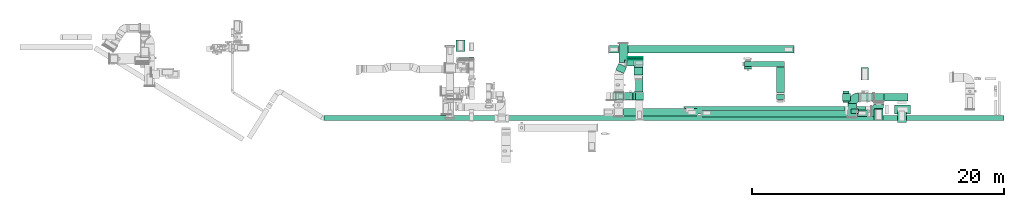
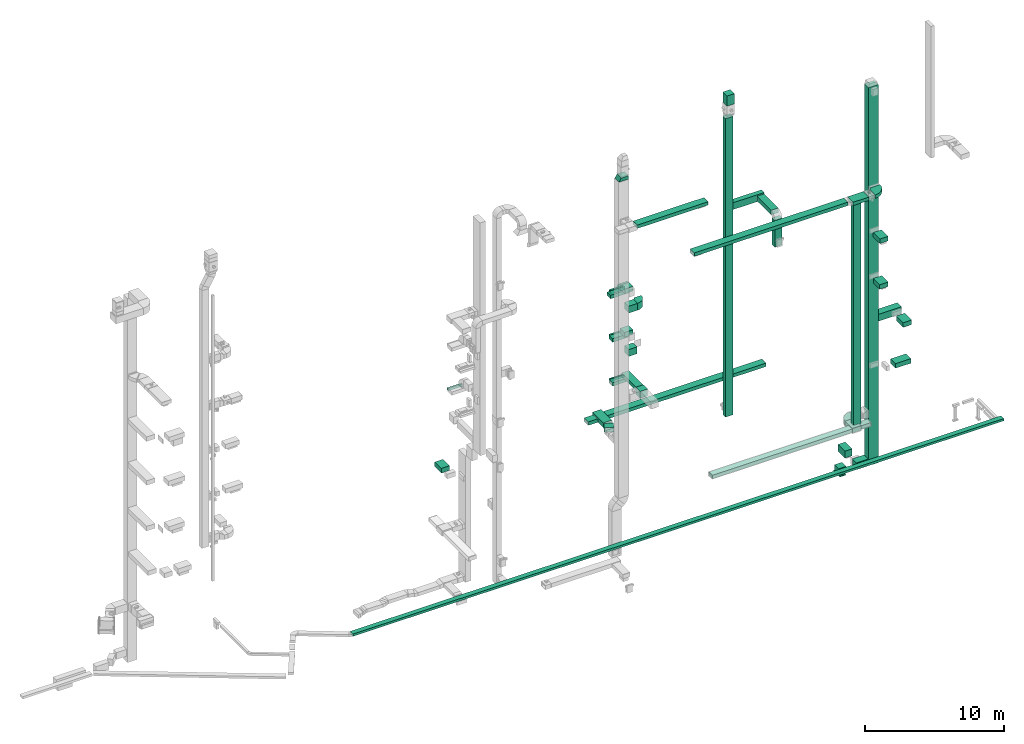
# One storey, part 8 of 29: 41 flow segments, 7 flow fittings, 2 flow terminals.
"""IFC2X3 building model written with IfcOpenShell, lengths in millimetres."""

import ifcopenshell
import ifcopenshell.guid

model = None  # the IFC model being written
_history = None  # IfcOwnerHistory: only IFC2X3 demands one
_inside = {}  # id of a spatial element -> (the spatial element, [elements in it])
_under = {}  # id of a project, library or spatial element -> (it, [spatial elements below it])
_declared = {}  # id of a project -> (the project, [libraries it declares])
_typed = {}  # id of a type object -> (the type object, [elements of that type])
_made_of = {}  # id of a material, layer set ... -> (it, [elements and type objects made of it])


def new_model(schema):
    """Start an empty IFC model of exactly this schema.

    Asked for "IFC4X3", IfcOpenShell would pick the latest addendum, in which some entities
    have other attributes; the version numbers below select the first issue.
    IFC2X3 requires an IfcOwnerHistory on every rooted entity: one is made here for all.
    """
    global model, _history
    if schema == "IFC4X3":
        model = ifcopenshell.file(schema_version=(4, 3, 0, 0))
    else:
        model = ifcopenshell.file(schema=schema)
    _inside.clear()
    _under.clear()
    _declared.clear()
    _typed.clear()
    _made_of.clear()
    _history = None
    if model.schema == "IFC2X3":
        org = make("IfcOrganization", Name="unknown")
        user = make(
            "IfcPersonAndOrganization",
            ThePerson=make("IfcPerson", FamilyName="unknown"),
            TheOrganization=org,
        )
        app = make(
            "IfcApplication",
            ApplicationDeveloper=org,
            Version="unknown",
            ApplicationFullName="unknown",
            ApplicationIdentifier="unknown",
        )
        _history = make(
            "IfcOwnerHistory",
            OwningUser=user,
            OwningApplication=app,
            ChangeAction="ADDED",
            CreationDate=0,
        )
    return model


def make(cls, **values):
    """One entity of the class cls with the attributes given. An attribute that is None is left unset."""
    return model.create_entity(
        cls, **{name: value for name, value in values.items() if value is not None}
    )


def entity(cls, *values):
    """Any entity or typed value of the class cls, its attributes in the order of the schema. None: left unset."""
    e = model.create_entity(cls)
    for i, value in enumerate(values):
        if value is not None:
            e[i] = value
    return e


def rooted(cls, **values):
    """An entity with a GlobalId (a new one), such as an element, a storey or a relation."""
    return make(cls, GlobalId=ifcopenshell.guid.new(), OwnerHistory=_history, **values)


def si_unit(unit_type, name, prefix=None):
    """IfcSIUnit, for example si_unit("LENGTHUNIT", "METRE", prefix="MILLI")."""
    return make("IfcSIUnit", UnitType=unit_type, Prefix=prefix, Name=name)


def converted_unit(unit_type, name, factor, base, dimensions=None, offset=None):
    """IfcConversionBasedUnit, such as the inch: factor (a typed value) times the base unit."""
    return make(
        "IfcConversionBasedUnit"
        if offset is None
        else "IfcConversionBasedUnitWithOffset",
        ConversionOffset=offset,
        Dimensions=None
        if dimensions is None
        else entity("IfcDimensionalExponents", *dimensions),
        UnitType=unit_type,
        Name=name,
        ConversionFactor=make(
            "IfcMeasureWithUnit", ValueComponent=factor, UnitComponent=base
        ),
    )


def derived_unit(unit_type, elements):
    """IfcDerivedUnit: a product of units, each with its exponent."""
    return make(
        "IfcDerivedUnit",
        Elements=[
            make("IfcDerivedUnitElement", Unit=unit, Exponent=power)
            for unit, power in elements
        ],
        UnitType=unit_type,
    )


def assignment(units):
    """IfcUnitAssignment: the units of a project."""
    return None if units is None else make("IfcUnitAssignment", Units=units)


def point(xyz):
    """IfcCartesianPoint."""
    return None if xyz is None else make("IfcCartesianPoint", Coordinates=xyz)


def direction(xyz):
    """IfcDirection."""
    return None if xyz is None else make("IfcDirection", DirectionRatios=xyz)


def frame(location, z_axis=None, x_axis=None):
    """IfcAxis2Placement3D, a coordinate frame: its origin and axes. An axis left out is left unset."""
    return make(
        "IfcAxis2Placement3D",
        Location=point(location),
        Axis=direction(z_axis),
        RefDirection=direction(x_axis),
    )


def frame_2d(location, x_axis=None):
    """IfcAxis2Placement2D, a coordinate frame in the plane: its origin and x axis."""
    return make(
        "IfcAxis2Placement2D", Location=point(location), RefDirection=direction(x_axis)
    )


def origin():
    """The frame at (0, 0, 0) with its axes left unset."""
    return frame((0.0, 0.0, 0.0))


def origin_2d_with_axis():
    """The frame at (0, 0) in the plane with the x axis (1, 0) written out."""
    return frame_2d((0.0, 0.0), x_axis=(1.0, 0.0))


def place(relative_to, where):
    """IfcLocalPlacement: puts the frame where relative to a parent placement (None: the world)."""
    return make(
        "IfcLocalPlacement", PlacementRelTo=relative_to, RelativePlacement=where
    )


def context(
    kind, dimensions, precision=None, world=None, true_north=None, identifier=None
):
    """IfcGeometricRepresentationContext, for example the 3D "Model" context."""
    return make(
        "IfcGeometricRepresentationContext",
        ContextIdentifier=identifier,
        ContextType=kind,
        CoordinateSpaceDimension=dimensions,
        Precision=precision,
        WorldCoordinateSystem=world,
        TrueNorth=true_north,
    )


def subcontext(parent, identifier, kind, view, scale=None):
    """IfcGeometricRepresentationSubContext, for example "Body" below "Model"."""
    return make(
        "IfcGeometricRepresentationSubContext",
        ContextIdentifier=identifier,
        ContextType=kind,
        ParentContext=parent,
        TargetScale=scale,
        TargetView=view,
    )


def project(units=None, contexts=None):
    """IfcProject with its units and contexts."""
    return rooted(
        "IfcProject",
        Name="project",
        RepresentationContexts=contexts,
        UnitsInContext=assignment(units),
    )


def spatial(cls, under=None, at=None, **own):
    """A site, building, storey or space (cls), placed at a placement, below another one or the project."""
    s = rooted(cls, ObjectPlacement=at, **own)
    if under is not None:
        _under.setdefault(under.id(), (under, []))[1].append(s)
    return s


def polyline(points):
    """IfcPolyline through the points."""
    return make("IfcPolyline", Points=[point(p) for p in points])


def circle_curve(where, radius):
    """IfcCircle in the frame where."""
    return make("IfcCircle", Position=where, Radius=radius)


def parameter(value):
    """IfcParameterValue: where a trimmed curve begins or ends, as a parameter of its basis curve."""
    return model.create_entity("IfcParameterValue", value)


def trimmed(basis, trim1, trim2, sense, master):
    """IfcTrimmedCurve: the piece of a basis curve between two trims."""
    return make(
        "IfcTrimmedCurve",
        BasisCurve=basis,
        Trim1=trim1,
        Trim2=trim2,
        SenseAgreement=sense,
        MasterRepresentation=master,
    )


def segment(curve, same_sense, transition):
    """IfcCompositeCurveSegment."""
    return make(
        "IfcCompositeCurveSegment",
        Transition=transition,
        SameSense=same_sense,
        ParentCurve=curve,
    )


def composite_curve(segments, self_intersect=None):
    """IfcCompositeCurve: segments joined end to end."""
    return make("IfcCompositeCurve", Segments=segments, SelfIntersect=self_intersect)


def profile(cls, at=None, kind="AREA", **sizes):
    """A parametric profile (cls). Its sizes go by their IFC names, for example OverallWidth=200.0."""
    return make(cls, ProfileType=kind, Position=at, **sizes)


def rectangle(**sizes):
    """IfcRectangleProfileDef."""
    return profile("IfcRectangleProfileDef", **sizes)


def outline(outer, holes=None, kind="AREA"):
    """IfcArbitraryClosedProfileDef: a profile drawn as a closed curve; with holes, ...WithVoids."""
    if holes is None:
        return make("IfcArbitraryClosedProfileDef", ProfileType=kind, OuterCurve=outer)
    return make(
        "IfcArbitraryProfileDefWithVoids",
        ProfileType=kind,
        OuterCurve=outer,
        InnerCurves=holes,
    )


def extrude(swept, where, along, depth):
    """IfcExtrudedAreaSolid: the profile swept, set in the frame where, extruded along a direction by depth."""
    return make(
        "IfcExtrudedAreaSolid",
        SweptArea=swept,
        Position=where,
        ExtrudedDirection=direction(along),
        Depth=depth,
    )


def shape(context_of_items, identifier, shape_type, items):
    """IfcShapeRepresentation: the items that make up one representation, for example the "Body"."""
    return make(
        "IfcShapeRepresentation",
        ContextOfItems=context_of_items,
        RepresentationIdentifier=identifier,
        RepresentationType=shape_type,
        Items=items,
    )


def source(mapping_origin, context_of_items, identifier, shape_type, items):
    """IfcRepresentationMap: a shape defined once, which mapped items show again and again."""
    return make(
        "IfcRepresentationMap",
        MappingOrigin=mapping_origin,
        MappedRepresentation=shape(context_of_items, identifier, shape_type, items),
    )


def transform(
    local_origin,
    x_axis=None,
    y_axis=None,
    z_axis=None,
    scale=None,
    scale2=None,
    scale3=None,
    uniform=True,
):
    """IfcCartesianTransformationOperator3D, or its non-uniform kind. x_axis, y_axis, z_axis: its Axis1, 2, 3."""
    if uniform:
        return make(
            "IfcCartesianTransformationOperator3D",
            Axis1=direction(x_axis),
            Axis2=direction(y_axis),
            LocalOrigin=point(local_origin),
            Scale=scale,
            Axis3=direction(z_axis),
        )
    return make(
        "IfcCartesianTransformationOperator3DnonUniform",
        Axis1=direction(x_axis),
        Axis2=direction(y_axis),
        LocalOrigin=point(local_origin),
        Scale=scale,
        Axis3=direction(z_axis),
        Scale2=scale2,
        Scale3=scale3,
    )


def mapped(mapping_source, mapping_target):
    """IfcMappedItem: shows the shape of a source again, moved by a transform."""
    return make(
        "IfcMappedItem", MappingSource=mapping_source, MappingTarget=mapping_target
    )


def material(Name=None, Category=None):
    """IfcMaterial."""
    return make("IfcMaterial", Name=Name, Category=Category)


def made_of(thing, what):
    """Note that an element or type object is made of a material, layer set ...; save() writes the relation."""
    if what is not None:
        _made_of.setdefault(what.id(), (what, []))[1].append(thing)
    return thing


def type_object(cls, material=None, **own):
    """A type object (cls), such as IfcWallType, which elements share."""
    return made_of(rooted(cls, **own), material)


def type_shapes(of_type, sources):
    """Give a type object the sources (RepresentationMaps) that its elements show as mapped items."""
    of_type.RepresentationMaps = sources


def element(
    cls,
    number,
    at=None,
    inside=None,
    cuts=None,
    type_object=None,
    material=None,
    context=None,
    identifier="Body",
    shape_type=None,
    held_by="IfcProductDefinitionShape",
    body=None,
    shapes=None,
    **own,
):
    """One element of the class cls, such as IfcWall. Its Tag is "e" and its number.

    at: its placement. inside: the storey or other place that contains it. cuts: it is an
    opening in that element (IfcRelVoidsElement). A single representation is given by context,
    identifier, shape_type and body (its items); several are given by shapes. held_by: the class
    of the entity that holds the representations. save() writes the other relations.
    """
    e = rooted(cls, Tag="e%d" % number, ObjectPlacement=at, **own)
    if body is not None:
        shapes = [shape(context, identifier, shape_type, body)]
    if shapes is not None:
        e.Representation = make(held_by, Representations=shapes)
    if inside is not None:
        _inside.setdefault(inside.id(), (inside, []))[1].append(e)
    if cuts is not None:
        rooted(
            "IfcRelVoidsElement", RelatingBuildingElement=cuts, RelatedOpeningElement=e
        )
    if type_object is not None:
        _typed.setdefault(type_object.id(), (type_object, []))[1].append(e)
    return made_of(e, material)


def aggregate(whole, parts):
    """IfcRelAggregates: a whole, such as a stair, and the parts it consists of."""
    return rooted("IfcRelAggregates", RelatingObject=whole, RelatedObjects=parts)


def save(model, path):
    """Write the relations noted so far, then the file.

    IfcRelAggregates (storeys below a building ...), IfcRelContainedInSpatialStructure (elements
    in a storey), IfcRelDefinesByType, IfcRelAssociatesMaterial and IfcRelDeclares: one each for
    every whole, place, type object, material and project.
    """
    for whole, parts in _under.values():
        aggregate(whole, parts)
    for where, things in _inside.values():
        rooted(
            "IfcRelContainedInSpatialStructure",
            RelatedElements=things,
            RelatingStructure=where,
        )
    for kind, things in _typed.values():
        rooted("IfcRelDefinesByType", RelatedObjects=things, RelatingType=kind)
    for what, things in _made_of.values():
        rooted("IfcRelAssociatesMaterial", RelatedObjects=things, RelatingMaterial=what)
    for by, libraries in _declared.values():
        rooted("IfcRelDeclares", RelatingContext=by, RelatedDefinitions=libraries)
    model.write(path)


model = new_model("IFC2X3")

# Units and contexts
model_context = context("Model", 3, precision=0.01, world=origin(), true_north=direction((6.12303176911189e-17, 1.0)))
body_context = subcontext(model_context, "Body", "Model", "MODEL_VIEW")
ifc_project = project(units=[si_unit("LENGTHUNIT", "METRE", prefix="MILLI"), si_unit("AREAUNIT", "SQUARE_METRE"), si_unit("VOLUMEUNIT", "CUBIC_METRE"), converted_unit("PLANEANGLEUNIT", "DEGREE", entity("IfcRatioMeasure", 0.0174532925199433), si_unit("PLANEANGLEUNIT", "RADIAN"), dimensions=[0, 0, 0, 0, 0, 0, 0]), si_unit("MASSUNIT", "GRAM", prefix="KILO"), derived_unit("MASSDENSITYUNIT", [(si_unit("MASSUNIT", "GRAM", prefix="KILO"), 1), (si_unit("LENGTHUNIT", "METRE"), -3)]), derived_unit("MOMENTOFINERTIAUNIT", [(si_unit("LENGTHUNIT", "METRE"), 4)]), si_unit("TIMEUNIT", "SECOND"), si_unit("FREQUENCYUNIT", "HERTZ"), si_unit("THERMODYNAMICTEMPERATUREUNIT", "DEGREE_CELSIUS"), derived_unit("THERMALTRANSMITTANCEUNIT", [(si_unit("MASSUNIT", "GRAM", prefix="KILO"), 1), (si_unit("THERMODYNAMICTEMPERATUREUNIT", "KELVIN"), -1), (si_unit("TIMEUNIT", "SECOND"), -3)]), derived_unit("VOLUMETRICFLOWRATEUNIT", [(si_unit("LENGTHUNIT", "METRE"), 3), (si_unit("TIMEUNIT", "SECOND"), -1)]), derived_unit("MASSFLOWRATEUNIT", [(si_unit("MASSUNIT", "GRAM", prefix="KILO"), 1), (si_unit("TIMEUNIT", "SECOND"), -1)]), derived_unit("ROTATIONALFREQUENCYUNIT", [(si_unit("TIMEUNIT", "SECOND"), -1)]), si_unit("ELECTRICCURRENTUNIT", "AMPERE"), si_unit("ELECTRICVOLTAGEUNIT", "VOLT"), si_unit("POWERUNIT", "WATT"), si_unit("FORCEUNIT", "NEWTON", prefix="KILO"), si_unit("ILLUMINANCEUNIT", "LUX"), si_unit("LUMINOUSFLUXUNIT", "LUMEN"), si_unit("LUMINOUSINTENSITYUNIT", "CANDELA"), derived_unit("USERDEFINED", [(si_unit("MASSUNIT", "GRAM", prefix="KILO"), -1), (si_unit("LENGTHUNIT", "METRE"), -2), (si_unit("TIMEUNIT", "SECOND"), 3), (si_unit("LUMINOUSFLUXUNIT", "LUMEN"), 1)]), derived_unit("LINEARVELOCITYUNIT", [(si_unit("LENGTHUNIT", "METRE"), 1), (si_unit("TIMEUNIT", "SECOND"), -1)]), si_unit("PRESSUREUNIT", "PASCAL"), derived_unit("USERDEFINED", [(si_unit("LENGTHUNIT", "METRE"), -2), (si_unit("MASSUNIT", "GRAM", prefix="KILO"), 1), (si_unit("TIMEUNIT", "SECOND"), -2)]), derived_unit("LINEARFORCEUNIT", [(si_unit("MASSUNIT", "GRAM", prefix="KILO"), 1), (si_unit("LENGTHUNIT", "METRE"), 1), (si_unit("TIMEUNIT", "SECOND"), -2), (si_unit("LENGTHUNIT", "METRE"), -1)]), derived_unit("PLANARFORCEUNIT", [(si_unit("MASSUNIT", "GRAM", prefix="KILO"), 1), (si_unit("LENGTHUNIT", "METRE"), 1), (si_unit("TIMEUNIT", "SECOND"), -2), (si_unit("LENGTHUNIT", "METRE"), -2)])], contexts=[model_context])

# Site, building, storey
site_placement = place(None, frame((0.0, -0.00077364408347762, 0.0)))
site = spatial("IfcSite", under=ifc_project, at=site_placement, CompositionType="ELEMENT")
building_placement = place(site_placement, origin())
building = spatial("IfcBuilding", under=site, at=building_placement, CompositionType="ELEMENT")
storey_placement = place(building_placement, origin())
storey = spatial("IfcBuildingStorey", under=building, at=storey_placement, CompositionType="ELEMENT", Elevation=0.0)

# Flow segments
duct_segment_type = type_object("IfcDuctSegmentType", PredefinedType="NOTDEFINED")
flow_segment_1_placement = place(storey_placement, frame((29480.9402422403, 13826.024832867, 14200.0)))
element("IfcFlowSegment", 1, at=flow_segment_1_placement, inside=storey, type_object=duct_segment_type, context=body_context, shape_type="SweptSolid", body=[
    extrude(rectangle(XDim=149.999999999951, YDim=1200.0, at=frame_2d((-1.08002495835535e-12, 2.1600499167107e-12), x_axis=(1.0, 0.0))), frame((600.0, 75.0, 0.0), z_axis=(0.0, 0.0, 1.0), x_axis=(0.0, -1.0, 0.0)), (0.0, 0.0, 1.0), 199.999999999998),
])
flow_segment_2_placement = place(storey_placement, frame((29270.0506788633, 14439.7047576879, 6700.0)))
element("IfcFlowSegment", 2, at=flow_segment_2_placement, inside=storey, type_object=duct_segment_type, context=body_context, shape_type="SweptSolid", body=[
    extrude(rectangle(XDim=937.535158670706, YDim=700.000000000001, at=frame_2d((-2.1600499167107e-12, 2.1600499167107e-12), x_axis=(1.0, 0.0))), frame((350.0, 468.767579335354, 0.0), z_axis=(0.0, 0.0, 1.0), x_axis=(0.0, -1.0, 0.0)), (0.0, 0.0, 1.0), 400.0),
])
flow_segment_3_placement = place(storey_placement, frame((52184.9665847859, 13247.5127880083, 4300.0)))
element("IfcFlowSegment", 3, at=flow_segment_3_placement, inside=storey, type_object=duct_segment_type, context=body_context, shape_type="SweptSolid", body=[
    extrude(rectangle(XDim=400.0, YDim=600.000000000002, at=frame_2d((2.17426077142591e-12, 0.0), x_axis=(1.0, 0.0))), frame((300.0, 200.0, 0.0), z_axis=(0.0, 0.0, 1.0), x_axis=(0.0, 1.0, 0.0)), (0.0, 0.0, 1.0), 26200.0),
])
flow_segment_4_placement = place(storey_placement, frame((52804.9665847859, 13249.5127880083, 22300.0)))
element("IfcFlowSegment", 4, at=flow_segment_4_placement, inside=storey, type_object=duct_segment_type, context=body_context, shape_type="SweptSolid", body=[
    extrude(rectangle(XDim=2571.24040529866, YDim=400.0, at=frame_2d((0.0, 1.09423581307055e-12), x_axis=(1.0, 0.0))), frame((1285.62020264933, 200.0, 0.0)), (0.0, 0.0, 1.0), 600.000000000002),
])
flow_segment_5_placement = place(storey_placement, frame((54760.3009666719, 11177.5127880084, 22400.0)))
element("IfcFlowSegment", 5, at=flow_segment_5_placement, inside=storey, type_object=duct_segment_type, context=body_context, shape_type="SweptSolid", body=[
    extrude(rectangle(XDim=2051.99999999995, YDim=600.000000000002, at=origin_2d_with_axis()), frame((300.0, 1026.0, 0.0), z_axis=(0.0, 0.0, 1.0), x_axis=(0.0, -1.0, 0.0)), (0.0, 0.0, 1.0), 399.999999999996),
])
flow_segment_6_placement = place(storey_placement, frame((54760.3009666719, 10627.5127880084, 19900.0)))
element("IfcFlowSegment", 6, at=flow_segment_6_placement, inside=storey, type_object=duct_segment_type, context=body_context, shape_type="SweptSolid", body=[
    extrude(rectangle(XDim=600.000000000002, YDim=400.0, at=origin_2d_with_axis()), frame((300.0, 200.0, 0.0)), (0.0, 0.0, 1.0), 2350.0),
])
flow_segment_7_placement = place(storey_placement, frame((62470.5867868058, 10508.5000111377, -1899.5130110314)))
element("IfcFlowSegment", 7, at=flow_segment_7_placement, inside=storey, type_object=duct_segment_type, context=body_context, shape_type="SweptSolid", body=[
    extrude(rectangle(XDim=600.000000000002, YDim=800.0, at=frame_2d((-1.10844666778576e-12, 0.0), x_axis=(1.0, 0.0))), frame((400.0, 300.0, 0.0), z_axis=(0.0, 0.0, 1.0), x_axis=(0.0, 1.0, 0.0)), (0.0, 0.0, 1.0), 33180.0000000001),
])
flow_segment_8_placement = place(storey_placement, frame((47415.3380896129, 9499.95823990583, 22350.0)))
element("IfcFlowSegment", 8, at=flow_segment_8_placement, inside=storey, type_object=duct_segment_type, context=body_context, shape_type="SweptSolid", body=[
    extrude(rectangle(XDim=12760.06238009, YDim=599.999999999999, at=frame_2d((-4.09272615797818e-12, 1.62003743753303e-12), x_axis=(1.0, 0.0))), frame((6380.03558498176, 300.09348064401, 0.0), z_axis=(0.0, 0.0, 1.0), x_axis=(-1.0, -1.46520719766494e-05, 0.0)), (0.0, 0.0, 1.0), 300.000000000001),
])
flow_segment_9_placement = place(storey_placement, frame((60654.8486253537, 9545.44969494266, 2395.0)))
element("IfcFlowSegment", 9, at=flow_segment_9_placement, inside=storey, type_object=duct_segment_type, context=body_context, shape_type="SweptSolid", body=[
    extrude(rectangle(XDim=624.999999999996, YDim=325.000000000001, at=frame_2d((0.0, -5.40012479177676e-13), x_axis=(1.0, 0.0))), frame((312.499999999998, 162.500000000004, 0.0), z_axis=(0.0, 0.0, 1.0), x_axis=(-1.0, 0.0, 0.0)), (0.0, 0.0, 1.0), 19935.0),
])
flow_segment_10_placement = place(storey_placement, frame((63290.5867868058, 10508.500011138, 10500.0)))
element("IfcFlowSegment", 10, at=flow_segment_10_placement, inside=storey, type_object=duct_segment_type, context=body_context, shape_type="SweptSolid", body=[
    extrude(rectangle(XDim=1899.05121432152, YDim=600.0, at=frame_2d((0.0, 1.08002495835535e-12), x_axis=(1.0, 0.0))), frame((949.525607160761, 300.0, 0.0)), (0.0, 0.0, 1.0), 600.000000000002),
])
flow_segment_11_placement = place(storey_placement, frame((62507.045708819, 8974.8380040819, 14500.0)))
element("IfcFlowSegment", 11, at=flow_segment_11_placement, inside=storey, type_object=duct_segment_type, context=body_context, shape_type="SweptSolid", body=[
    extrude(rectangle(XDim=924.752466860906, YDim=699.999999999997, at=frame_2d((0.0, -8.66862137627322e-12), x_axis=(1.0, 0.0))), frame((350.0, 462.376233430453, 0.0), z_axis=(0.0, 0.0, 1.0), x_axis=(0.0, -1.0, 0.0)), (0.0, 0.0, 1.0), 400.0),
])
flow_segment_12_placement = place(storey_placement, frame((62519.0355390978, 8984.83800408189, 18500.0)))
element("IfcFlowSegment", 12, at=flow_segment_12_placement, inside=storey, type_object=duct_segment_type, context=body_context, shape_type="SweptSolid", body=[
    extrude(rectangle(XDim=947.818216633924, YDim=699.999999999997, at=origin_2d_with_axis()), frame((350.0, 473.909108316962, 0.0), z_axis=(0.0, 0.0, 1.0), x_axis=(0.0, 1.0, 0.0)), (0.0, 0.0, 1.0), 400.0),
])
flow_segment_13_placement = place(storey_placement, frame((48788.4460275147, 9267.33562411096, 2500.0)))
element("IfcFlowSegment", 13, at=flow_segment_13_placement, inside=storey, type_object=duct_segment_type, context=body_context, shape_type="SweptSolid", body=[
    extrude(rectangle(XDim=11604.0416533364, YDim=500.0, at=frame_2d((-4.09272615797818e-12, -5.40012479177676e-13), x_axis=(1.0, 0.0))), frame((5802.02094023152, 250.002635600499, 0.0)), (0.0, 0.0, 1.0), 300.0),
])
flow_segment_14_placement = place(storey_placement, frame((61132.5004629828, 9300.08046605657, 2500.0)))
element("IfcFlowSegment", 14, at=flow_segment_14_placement, inside=storey, type_object=duct_segment_type, context=body_context, shape_type="SweptSolid", body=[
    extrude(rectangle(XDim=831.78346095215, YDim=499.999999999999, at=frame_2d((-4.34852154285181e-12, 0.0), x_axis=(1.0, 0.0))), frame((415.891730476079, 250.0, 0.0), z_axis=(0.0, 0.0, 1.0), x_axis=(-1.0, 0.0, 0.0)), (0.0, 0.0, 1.0), 300.0),
])
flow_segment_15_placement = place(storey_placement, frame((59985.3187894594, 10508.5000111377, -1899.51301103139)))
element("IfcFlowSegment", 15, at=flow_segment_15_placement, inside=storey, type_object=duct_segment_type, context=body_context, shape_type="SweptSolid", body=[
    extrude(rectangle(XDim=632.577535598582, YDim=600.0, at=frame_2d((-8.66862137627322e-12, 1.08002495835535e-12), x_axis=(1.0, 0.0))), frame((316.288767799282, 300.0, 0.0), z_axis=(0.0, 0.0, 1.0), x_axis=(-1.0, 0.0, 0.0)), (0.0, 0.0, 1.0), 600.0),
])
flow_segment_16_placement = place(storey_placement, frame((61470.135994513, 12189.7209489757, -1899.51301103139)))
element("IfcFlowSegment", 16, at=flow_segment_16_placement, inside=storey, type_object=duct_segment_type, context=body_context, shape_type="SweptSolid", body=[
    extrude(rectangle(XDim=1004.44112420994, YDim=600.000000000002, at=frame_2d((-2.18847162614111e-12, 4.34852154285181e-12), x_axis=(1.0, 0.0))), frame((300.0, 502.220562104969, 0.0), z_axis=(0.0, 0.0, 1.0), x_axis=(0.0, -1.0, 0.0)), (0.0, 0.0, 1.0), 600.0),
])
flow_segment_17_placement = place(storey_placement, frame((60021.6146148951, 10407.3520030518, -1980.0)))
element("IfcFlowSegment", 17, at=flow_segment_17_placement, inside=storey, type_object=duct_segment_type, context=body_context, shape_type="SweptSolid", body=[
    extrude(rectangle(XDim=900.000000000001, YDim=499.999999999997, at=frame_2d((-1.08002495835535e-12, 0.0), x_axis=(1.0, 0.0))), frame((250.002313479293, 450.001285262157, 0.0), z_axis=(0.0, 0.0, 1.0), x_axis=(-5.14107242270256e-06, -1.0, 0.0)), (0.0, 0.0, 1.0), 60.4869889686082),
])
flow_segment_18_placement = place(storey_placement, frame((61457.896325058, 10508.5000111377, -1899.51301103139)))
element("IfcFlowSegment", 18, at=flow_segment_18_placement, inside=storey, type_object=duct_segment_type, context=body_context, shape_type="SweptSolid", body=[
    extrude(rectangle(XDim=992.690461747766, YDim=600.0, at=frame_2d((-4.32009983342141e-12, 1.08002495835535e-12), x_axis=(1.0, 0.0))), frame((496.345230873879, 300.0, 0.0), z_axis=(0.0, 0.0, 1.0), x_axis=(-1.0, 0.0, 0.0)), (0.0, 0.0, 1.0), 600.0),
])
flow_segment_19_placement = place(storey_placement, frame((18783.2756291013, 8980.00003916104, -650.0)))
element("IfcFlowSegment", 19, at=flow_segment_19_placement, inside=storey, type_object=duct_segment_type, context=body_context, shape_type="SweptSolid", body=[
    extrude(rectangle(XDim=54040.2939500627, YDim=400.0, at=frame_2d((5.45696821063757e-12, -5.54223333892878e-13), x_axis=(1.0, 0.0))), frame((27020.1469750313, 200.0, 0.0), z_axis=(0.0, 0.0, 1.0), x_axis=(-1.0, 0.0, 0.0)), (0.0, 0.0, 1.0), 200.0),
])
flow_segment_20_placement = place(storey_placement, frame((42574.8655210282, 9319.58124580587, 26600.0)))
element("IfcFlowSegment", 20, at=flow_segment_20_placement, inside=storey, type_object=duct_segment_type, context=body_context, shape_type="SweptSolid", body=[
    extrude(rectangle(XDim=5885.0094274255, YDim=600.0, at=frame_2d((-4.32009983342141e-12, 0.0), x_axis=(1.0, 0.0))), frame((2942.50471371275, 300.0, 0.0), z_axis=(0.0, 0.0, 1.0), x_axis=(-1.0, 0.0, 0.0)), (0.0, 0.0, 1.0), 300.000000000001),
])
flow_segment_21_placement = place(storey_placement, frame((42604.8655138023, 10584.9897523207, 18400.0)))
element("IfcFlowSegment", 21, at=flow_segment_21_placement, inside=storey, type_object=duct_segment_type, context=body_context, shape_type="SweptSolid", body=[
    extrude(rectangle(XDim=725.674377856759, YDim=600.0, at=frame_2d((4.32009983342141e-12, 0.0), x_axis=(1.0, 0.0))), frame((362.837188928384, 300.0, 0.0)), (0.0, 0.0, 1.0), 600.000000000002),
])
flow_segment_22_placement = place(storey_placement, frame((43430.5398916592, 12587.4891060609, 18600.0)))
element("IfcFlowSegment", 22, at=flow_segment_22_placement, inside=storey, type_object=duct_segment_type, context=body_context, shape_type="SweptSolid", body=[
    extrude(rectangle(XDim=600.000000000067, YDim=699.999999999997, at=origin_2d_with_axis()), frame((350.0, 300.0, 0.0), z_axis=(0.0, 0.0, 1.0), x_axis=(0.0, -1.0, 0.0)), (0.0, 0.0, 1.0), 400.0),
])
flow_segment_23_placement = place(storey_placement, frame((43542.9699383063, 10584.9897523207, 10600.0)))
element("IfcFlowSegment", 23, at=flow_segment_23_placement, inside=storey, type_object=duct_segment_type, context=body_context, shape_type="SweptSolid", body=[
    extrude(rectangle(XDim=621.895575496119, YDim=600.0, at=frame_2d((0.0, 1.08002495835535e-12), x_axis=(1.0, 0.0))), frame((310.94778774806, 300.0, 0.0)), (0.0, 0.0, 1.0), 599.999999999998),
])
flow_segment_24_placement = place(storey_placement, frame((43550.6022983322, 11204.9897523207, 10900.0)))
element("IfcFlowSegment", 24, at=flow_segment_24_placement, inside=storey, type_object=duct_segment_type, context=body_context, shape_type="SweptSolid", body=[
    extrude(rectangle(XDim=2055.01024767937, YDim=600.000000000002, at=frame_2d((1.02318153949454e-12, -4.34852154285181e-12), x_axis=(1.0, 0.0))), frame((300.0, 1027.50512383968, 0.0), z_axis=(0.0, 0.0, 1.0), x_axis=(0.0, 1.0, 0.0)), (0.0, 0.0, 1.0), 300.000000000001),
])
flow_segment_25_placement = place(storey_placement, frame((42920.5398916591, 13807.4891060585, 18000.0)))
element("IfcFlowSegment", 25, at=flow_segment_25_placement, inside=storey, type_object=duct_segment_type, context=body_context, shape_type="SweptSolid", body=[
    extrude(rectangle(XDim=167.510937173448, YDim=1200.0, at=frame_2d((-1.08002495835535e-12, 0.0), x_axis=(1.0, 0.0))), frame((600.0, 83.7554685867249, 0.0), z_axis=(0.0, 0.0, 1.0), x_axis=(0.0, -1.0, 0.0)), (0.0, 0.0, 1.0), 300.000000000001),
])
flow_segment_26_placement = place(storey_placement, frame((42667.670564287, 13287.4891060585, 18000.0)))
element("IfcFlowSegment", 26, at=flow_segment_26_placement, inside=storey, type_object=duct_segment_type, context=body_context, shape_type="SweptSolid", body=[
    extrude(rectangle(XDim=1480.0, YDim=499.999999999999, at=frame_2d((4.32009983342141e-12, 0.0), x_axis=(1.0, 0.0))), frame((740.0, 250.0, 0.0)), (0.0, 0.0, 1.0), 300.000000000001),
])
flow_segment_27_placement = place(storey_placement, frame((43410.2593646877, 12584.9897523208, 14800.0)))
element("IfcFlowSegment", 27, at=flow_segment_27_placement, inside=storey, type_object=duct_segment_type, context=body_context, shape_type="SweptSolid", body=[
    extrude(rectangle(XDim=632.499353737754, YDim=699.999999999997, at=origin_2d_with_axis()), frame((350.0, 316.249676868877, 0.0), z_axis=(0.0, 0.0, 1.0), x_axis=(0.0, -1.0, 0.0)), (0.0, 0.0, 1.0), 400.0),
])
flow_segment_28_placement = place(storey_placement, frame((42920.5398916591, 13837.4891060585, 14100.0)))
element("IfcFlowSegment", 28, at=flow_segment_28_placement, inside=storey, type_object=duct_segment_type, context=body_context, shape_type="SweptSolid", body=[
    extrude(rectangle(XDim=137.510937173448, YDim=1200.0, at=origin_2d_with_axis()), frame((600.0, 68.755468586724, 0.0), z_axis=(0.0, 0.0, 1.0), x_axis=(0.0, -1.0, 0.0)), (0.0, 0.0, 1.0), 300.000000000001),
])
flow_segment_29_placement = place(storey_placement, frame((42847.670564287, 13317.4891060585, 14100.0)))
element("IfcFlowSegment", 29, at=flow_segment_29_placement, inside=storey, type_object=duct_segment_type, context=body_context, shape_type="SweptSolid", body=[
    extrude(rectangle(XDim=1300.00000000001, YDim=499.999999999999, at=frame_2d((4.32009983342141e-12, -1.09423581307055e-12), x_axis=(1.0, 0.0))), frame((650.0, 250.0, 0.0), z_axis=(0.0, 0.0, 1.0), x_axis=(-1.0, 0.0, 0.0)), (0.0, 0.0, 1.0), 300.000000000001),
])
flow_segment_30_placement = place(storey_placement, frame((42847.670564287, 13317.4891060585, 10250.0)))
element("IfcFlowSegment", 30, at=flow_segment_30_placement, inside=storey, type_object=duct_segment_type, context=body_context, shape_type="SweptSolid", body=[
    extrude(rectangle(XDim=1300.0, YDim=499.999999999999, at=frame_2d((0.0, -1.09423581307055e-12), x_axis=(1.0, 0.0))), frame((650.0, 250.0, 0.0), z_axis=(0.0, 0.0, 1.0), x_axis=(-1.0, 0.0, 0.0)), (0.0, 0.0, 1.0), 300.000000000001),
])
flow_segment_31_placement = place(storey_placement, frame((41966.3691390541, 12696.4261246615, 6700.0)))
element("IfcFlowSegment", 31, at=flow_segment_31_placement, inside=storey, type_object=duct_segment_type, context=body_context, shape_type="SweptSolid", body=[
    extrude(rectangle(XDim=554.821864390223, YDim=700.000000000004, at=frame_2d((-9.66338120633736e-13, -4.54747350886464e-13), x_axis=(1.0, 0.0))), frame((435.334776455149, 401.068751016331, 0.0), z_axis=(0.0, 0.0, 1.0), x_axis=(0.430524152786573, 0.902579056851755, 0.0)), (0.0, 0.0, 1.0), 400.0),
])
flow_segment_32_placement = place(storey_placement, frame((42939.8464936403, 14330.0652551759, 6700.0)))
element("IfcFlowSegment", 32, at=flow_segment_32_placement, inside=storey, type_object=duct_segment_type, context=body_context, shape_type="SweptSolid", body=[
    extrude(rectangle(XDim=13206.0535856904, YDim=600.0, at=frame_2d((-4.09272615797818e-12, 1.08002495835535e-12), x_axis=(1.0, 0.0))), frame((6603.02679284522, 300.0, 0.0), z_axis=(0.0, 0.0, 1.0), x_axis=(-1.0, 0.0, 0.0)), (0.0, 0.0, 1.0), 300.000000000001),
])
flow_segment_33_placement = place(storey_placement, frame((41411.7933143667, 14330.0650296545, 6700.0)))
element("IfcFlowSegment", 33, at=flow_segment_33_placement, inside=storey, type_object=duct_segment_type, context=body_context, shape_type="SweptSolid", body=[
    extrude(rectangle(XDim=788.053179273669, YDim=600.0, at=origin_2d_with_axis()), frame((394.026589636834, 300.0, 0.0)), (0.0, 0.0, 1.0), 300.000000000001),
])
flow_segment_34_placement = place(storey_placement, frame((42219.8464936403, 13563.1422496121, 6700.0)))
element("IfcFlowSegment", 34, at=flow_segment_34_placement, inside=storey, type_object=duct_segment_type, context=body_context, shape_type="SweptSolid", body=[
    extrude(rectangle(XDim=1542.05774942284, YDim=699.999999999997, at=frame_2d((1.08002495835535e-12, 0.0), x_axis=(1.0, 0.0))), frame((350.0, 771.028874711431, 0.0), z_axis=(0.0, 0.0, 1.0), x_axis=(0.0, 1.0, 0.0)), (0.0, 0.0, 1.0), 400.0),
])
flow_segment_35_placement = place(storey_placement, frame((42920.5398916591, 13837.4891060585, 10300.0)))
element("IfcFlowSegment", 35, at=flow_segment_35_placement, inside=storey, type_object=duct_segment_type, context=body_context, shape_type="SweptSolid", body=[
    extrude(rectangle(XDim=137.510893630899, YDim=1200.0, at=frame_2d((1.08002495835535e-12, 0.0), x_axis=(1.0, 0.0))), frame((600.0, 68.7554468154507, 0.0), z_axis=(0.0, 0.0, 1.0), x_axis=(0.0, -1.0, 0.0)), (0.0, 0.0, 1.0), 199.999999999998),
])
flow_segment_36_placement = place(storey_placement, frame((60475.0932034313, 9299.13314034304, 22350.0)))
element("IfcFlowSegment", 36, at=flow_segment_36_placement, inside=storey, type_object=duct_segment_type, context=body_context, shape_type="SweptSolid", body=[
    extrude(rectangle(XDim=1324.08735347574, YDim=800.0, at=frame_2d((4.32009983342141e-12, 0.0), x_axis=(1.0, 0.0))), frame((662.292829977412, 400.412510926887, 0.0), z_axis=(0.0, 0.0, 1.0), x_axis=(-0.999999805808052, 0.000623204507744216, 0.0)), (0.0, 0.0, 1.0), 300.000000000001),
])
flow_segment_37_placement = place(storey_placement, frame((60412.5004629827, 9250.08574557039, 2450.0)))
element("IfcFlowSegment", 37, at=flow_segment_37_placement, inside=storey, type_object=duct_segment_type, context=body_context, shape_type="SweptSolid", body=[
    extrude(rectangle(XDim=1058.41426556729, YDim=699.999999999997, at=frame_2d((1.59161572810262e-12, 4.32009983342141e-12), x_axis=(1.0, 0.0))), frame((350.0, 529.207132783651, 0.0), z_axis=(0.0, 0.0, 1.0), x_axis=(0.0, -1.0, 0.0)), (0.0, 0.0, 1.0), 400.0),
])
flow_segment_38_placement = place(storey_placement, frame((64109.9985523544, 9485.42147047353, 6700.0)))
element("IfcFlowSegment", 38, at=flow_segment_38_placement, inside=storey, type_object=duct_segment_type, context=body_context, shape_type="SweptSolid", body=[
    extrude(rectangle(XDim=1288.00000000007, YDim=700.0, at=frame_2d((8.69704308570363e-12, 5.40012479177676e-13), x_axis=(1.0, 0.0))), frame((644.0, 350.0, 0.0)), (0.0, 0.0, 1.0), 400.0),
])
flow_segment_39_placement = place(storey_placement, frame((64372.3454684373, 8827.65633112709, 10600.0)))
element("IfcFlowSegment", 39, at=flow_segment_39_placement, inside=storey, type_object=duct_segment_type, context=body_context, shape_type="SweptSolid", body=[
    extrude(rectangle(XDim=998.000000000008, YDim=699.999999999997, at=frame_2d((-5.40012479177676e-13, -4.32009983342141e-12), x_axis=(1.0, 0.0))), frame((350.0, 499.0, 0.0), z_axis=(0.0, 0.0, 1.0), x_axis=(0.0, -1.0, 0.0)), (0.0, 0.0, 1.0), 400.0),
])
flow_segment_40_placement = place(storey_placement, frame((42604.8655138023, 10584.989752321, 14600.0)))
element("IfcFlowSegment", 40, at=flow_segment_40_placement, inside=storey, type_object=duct_segment_type, context=body_context, shape_type="SweptSolid", body=[
    extrude(rectangle(XDim=705.39385088537, YDim=600.0, at=frame_2d((4.32009983342141e-12, -1.08002495835535e-12), x_axis=(1.0, 0.0))), frame((352.69692544268, 300.0, 0.0), z_axis=(0.0, 0.0, 1.0), x_axis=(-1.0, 0.0, 0.0)), (0.0, 0.0, 1.0), 600.000000000002),
])
flow_segment_41_placement = place(storey_placement, frame((52184.9665847859, 13047.5127880084, 31710.0)))
element("IfcFlowSegment", 41, at=flow_segment_41_placement, inside=storey, type_object=duct_segment_type, context=body_context, shape_type="SweptSolid", body=[
    extrude(rectangle(XDim=600.0, YDim=600.000000000002, at=frame_2d((1.08002495835535e-12, 0.0), x_axis=(1.0, 0.0))), frame((300.0, 300.0, 0.0), z_axis=(0.0, 0.0, 1.0), x_axis=(0.0, -1.0, 0.0)), (0.0, 0.0, 1.0), 890.000000000062),
])

# Flow terminal
ifc_material_1 = material()
air_terminal_type_1 = type_object("IfcAirTerminalType", PredefinedType="NOTDEFINED", material=ifc_material_1)
shared_shape_1 = source(origin(), body_context, "Body", "SweptSolid", [
    extrude(rectangle(XDim=4.0, YDim=1200.0, at=origin_2d_with_axis()), frame((0.0, -2.0, -100.0), z_axis=(0.0, 0.0, 1.0), x_axis=(0.0, 1.0, 0.0)), (0.0, 0.0, 1.0), 200.000000000005),
])
type_shapes(air_terminal_type_1, [shared_shape_1])
flow_terminal_1_placement = place(storey_placement, frame((43520.5398916591, 13975.0, 10400.0), z_axis=(0.0, 0.0, 1.0), x_axis=(-1.0, 0.0, 0.0)))
element("IfcFlowTerminal", 42, at=flow_terminal_1_placement, inside=storey, type_object=air_terminal_type_1, material=ifc_material_1, context=body_context, shape_type="MappedRepresentation", body=[
    mapped(shared_shape_1, transform((0.0, 0.0, 0.0), scale=1.0)),
])

# Flow fittings
ifc_material_2 = material()
duct_fitting_type_1 = type_object("IfcDuctFittingType", PredefinedType="NOTDEFINED", material=ifc_material_2)
shared_shape_2 = source(origin(), body_context, "Body", "SweptSolid", [
    extrude(outline(composite_curve([segment(polyline([(-675.0, -275.0), (125.0, -275.0)]), True, "CONTINUOUS"), segment(trimmed(circle_curve(frame_2d((275.0, -275.0), x_axis=(0.0, 1.0)), 150.0), [parameter(0.0)], [parameter(90.0000000000001)], True, "PARAMETER"), False, "CONTINUOUS"), segment(polyline([(275.0, -125.0), (275.0, 675.0)]), True, "CONTINUOUS"), segment(trimmed(circle_curve(frame_2d((275.0, -275.0), x_axis=(0.0, 1.0)), 950.0), [parameter(0.0)], [parameter(90.0000000000001)], True, "PARAMETER"), True, "CONTINUOUS")], self_intersect=False)), frame((-275.0, 275.0, -150.0), z_axis=(0.0, 0.0, 1.0), x_axis=(-1.0, 0.0, 0.0)), (0.0, 0.0, 1.0), 300.0),
])
type_shapes(duct_fitting_type_1, [shared_shape_2])
flow_fitting_1_placement = place(storey_placement, frame((62869.7193441202, 9698.83392450256, 22500.0)))
element("IfcFlowFitting", 43, at=flow_fitting_1_placement, inside=storey, type_object=duct_fitting_type_1, material=ifc_material_2, context=body_context, shape_type="MappedRepresentation", body=[
    mapped(shared_shape_2, transform((0.0, 0.0, 0.0), scale=1.0)),
])
duct_fitting_type_2 = type_object("IfcDuctFittingType", PredefinedType="NOTDEFINED", material=ifc_material_2)
shared_shape_3 = source(origin(), body_context, "Body", "SweptSolid", [
    extrude(outline(composite_curve([segment(polyline([(-600.0, -250.0), (100.0, -250.0)]), True, "CONTINUOUS"), segment(trimmed(circle_curve(frame_2d((250.0, -250.0), x_axis=(0.0, 1.0)), 150.0), [parameter(0.0)], [parameter(90.0)], True, "PARAMETER"), False, "CONTINUOUS"), segment(polyline([(250.0, -100.0), (250.0, 600.0)]), True, "CONTINUOUS"), segment(trimmed(circle_curve(frame_2d((250.0, -250.0), x_axis=(0.0, 1.0)), 850.0), [parameter(0.0)], [parameter(90.0)], True, "PARAMETER"), True, "CONTINUOUS")], self_intersect=False)), frame((-250.0, 250.0, -200.0), z_axis=(0.0, 0.0, 1.0), x_axis=(-1.0, 0.0, 0.0)), (0.0, 0.0, 1.0), 400.0),
])
type_shapes(duct_fitting_type_2, [shared_shape_3])
flow_fitting_2_placement = place(storey_placement, frame((60762.5004629828, 10808.5000111377, 2650.0), z_axis=(0.0, 0.0, 1.0), x_axis=(-1.0, 0.0, 0.0)))
element("IfcFlowFitting", 44, at=flow_fitting_2_placement, inside=storey, type_object=duct_fitting_type_2, material=ifc_material_2, context=body_context, shape_type="MappedRepresentation", body=[
    mapped(shared_shape_3, transform((0.0, 0.0, 0.0), scale=1.0)),
])

# Flow terminal
air_terminal_type_2 = type_object("IfcAirTerminalType", PredefinedType="NOTDEFINED", material=ifc_material_1)
shared_shape_4 = source(origin(), body_context, "Body", "SweptSolid", [
    extrude(rectangle(XDim=4.0, YDim=1200.0, at=origin_2d_with_axis()), frame((0.0, -2.0, -150.0), z_axis=(0.0, 0.0, 1.0), x_axis=(0.0, 1.0, 0.0)), (0.0, 0.0, 1.0), 300.000000000005),
])
type_shapes(air_terminal_type_2, [shared_shape_4])
flow_terminal_2_placement = place(storey_placement, frame((43520.5398916591, 13975.0000432319, 18150.0), z_axis=(0.0, 0.0, -1.0), x_axis=(1.0, 0.0, 0.0)))
element("IfcFlowTerminal", 45, at=flow_terminal_2_placement, inside=storey, type_object=air_terminal_type_2, material=ifc_material_1, context=body_context, shape_type="MappedRepresentation", body=[
    mapped(shared_shape_4, transform((0.0, 0.0, 0.0), scale=1.0)),
])

# Flow fittings
duct_fitting_type_3 = type_object("IfcDuctFittingType", PredefinedType="NOTDEFINED", material=ifc_material_2)
shared_shape_5 = source(origin(), body_context, "Body", "SweptSolid", [
    extrude(rectangle(XDim=1200.0, YDim=26.0960000000043, at=frame_2d((-5.6843418860808e-14, 0.0), x_axis=(1.0, 0.0))), frame((6.95199999999999, 0.0, -150.0), z_axis=(0.0, 0.0, 1.0), x_axis=(0.0, -1.0, 0.0)), (0.0, 0.0, 1.0), 300.0),
])
type_shapes(duct_fitting_type_3, [shared_shape_5])
flow_fitting_3_placement = place(storey_placement, frame((43520.5398916591, 13787.4891060585, 18150.0), z_axis=(0.0, 0.0, -1.0), x_axis=(0.0, 1.0, 0.0)))
element("IfcFlowFitting", 46, at=flow_fitting_3_placement, inside=storey, type_object=duct_fitting_type_3, material=ifc_material_2, context=body_context, shape_type="MappedRepresentation", body=[
    mapped(shared_shape_5, transform((0.0, 0.0, 0.0), scale=1.0)),
])
duct_fitting_type_4 = type_object("IfcDuctFittingType", PredefinedType="NOTDEFINED", material=ifc_material_2)
shared_shape_6 = source(origin(), body_context, "Body", "SweptSolid", [
    extrude(rectangle(XDim=26.0960000000062, YDim=1200.0, at=frame_2d((-9.32587340685131e-13, -1.13686837721616e-13), x_axis=(1.0, 0.0))), frame((6.95199999999999, 0.0, -100.0)), (0.0, 0.0, 1.0), 200.0),
])
type_shapes(duct_fitting_type_4, [shared_shape_6])
flow_fitting_4_placement = place(storey_placement, frame((43520.5398916591, 13817.4891060585, 10400.0), z_axis=(0.0, 0.0, -1.0), x_axis=(0.0, 1.0, 0.0)))
element("IfcFlowFitting", 47, at=flow_fitting_4_placement, inside=storey, type_object=duct_fitting_type_4, material=ifc_material_2, context=body_context, shape_type="MappedRepresentation", body=[
    mapped(shared_shape_6, transform((0.0, 0.0, 0.0), scale=1.0)),
])
duct_fitting_type_5 = type_object("IfcDuctFittingType", PredefinedType="NOTDEFINED", material=ifc_material_2)
shared_shape_7 = source(origin(), body_context, "Body", "SweptSolid", [
    extrude(outline(composite_curve([segment(polyline([(-525.0, -225.0), (75.0, -225.0)]), True, "CONTINUOUS"), segment(trimmed(circle_curve(frame_2d((225.0, -225.0), x_axis=(0.0, 1.0)), 150.0), [parameter(0.0)], [parameter(90.0)], True, "PARAMETER"), False, "CONTINUOUS"), segment(polyline([(225.0, -75.0), (225.0, 525.0)]), True, "CONTINUOUS"), segment(trimmed(circle_curve(frame_2d((225.0, -225.0), x_axis=(0.0, 1.0)), 750.0), [parameter(0.0)], [parameter(90.0)], True, "PARAMETER"), True, "CONTINUOUS")], self_intersect=False)), frame((-225.0, 225.0, -300.0), z_axis=(0.0, 0.0, 1.0), x_axis=(-1.0, 0.0, 0.0)), (0.0, 0.0, 1.0), 600.0),
])
type_shapes(duct_fitting_type_5, [shared_shape_7])
flow_fitting_5_placement = place(storey_placement, frame((43780.5398916591, 10884.9897523207, 18700.0)))
element("IfcFlowFitting", 48, at=flow_fitting_5_placement, inside=storey, type_object=duct_fitting_type_5, material=ifc_material_2, context=body_context, shape_type="MappedRepresentation", body=[
    mapped(shared_shape_7, transform((0.0, 0.0, 0.0), scale=1.0)),
])
duct_fitting_type_6 = type_object("IfcDuctFittingType", PredefinedType="NOTDEFINED", material=ifc_material_2)
shared_shape_8 = source(origin(), body_context, "Body", "SweptSolid", [
    extrude(outline(composite_curve([segment(polyline([(-375.0, -175.0), (25.0, -175.0)]), True, "CONTINUOUS"), segment(trimmed(circle_curve(frame_2d((175.0, -175.0), x_axis=(0.0, 1.0)), 150.0), [parameter(0.0)], [parameter(90.0000000000001)], True, "PARAMETER"), False, "CONTINUOUS"), segment(polyline([(175.0, -25.0), (175.0, 375.0)]), True, "CONTINUOUS"), segment(trimmed(circle_curve(frame_2d((175.0, -175.0), x_axis=(0.0, 1.0)), 550.0), [parameter(0.0)], [parameter(90.0)], True, "PARAMETER"), True, "CONTINUOUS")], self_intersect=False)), frame((-175.0, 175.0, -350.0), z_axis=(0.0, 0.0, 1.0), x_axis=(-1.0, 0.0, 0.0)), (0.0, 0.0, 1.0), 700.0),
])
type_shapes(duct_fitting_type_6, [shared_shape_8])
flow_fitting_6_placement = place(storey_placement, frame((43780.5398916592, 13537.489106061, 18800.0), z_axis=(1.0, 0.0, 0.0), x_axis=(0.0, 0.0, 1.0)))
element("IfcFlowFitting", 49, at=flow_fitting_6_placement, inside=storey, type_object=duct_fitting_type_6, material=ifc_material_2, context=body_context, shape_type="MappedRepresentation", body=[
    mapped(shared_shape_8, transform((0.0, 0.0, 0.0), scale=1.0)),
])
duct_fitting_type_7 = type_object("IfcDuctFittingType", PredefinedType="NOTDEFINED", material=ifc_material_2)
shared_shape_9 = source(origin(), body_context, "Body", "SweptSolid", [
    extrude(outline(polyline([(-150.0, -350.0), (150.0, -350.0), (150.0, 250.0), (-150.0, 450.0), (-150.0, -350.0)])), frame((150.0, -300.0, 50.0), z_axis=(0.0, 1.0, 0.0), x_axis=(1.0, 0.0, 0.0)), (0.0, 0.0, 1.0), 600.0),
])
type_shapes(duct_fitting_type_7, [shared_shape_9])
flow_fitting_7_placement = place(storey_placement, frame((42184.8655138024, 10884.9897523209, 30169.6210853378), z_axis=(1.0, 0.0, 0.0), x_axis=(0.0, 0.0, 1.0)))
element("IfcFlowFitting", 50, at=flow_fitting_7_placement, inside=storey, type_object=duct_fitting_type_7, material=ifc_material_2, context=body_context, shape_type="MappedRepresentation", body=[
    mapped(shared_shape_9, transform((0.0, 0.0, 0.0), scale=1.0)),
])

save(model, "model.ifc")
